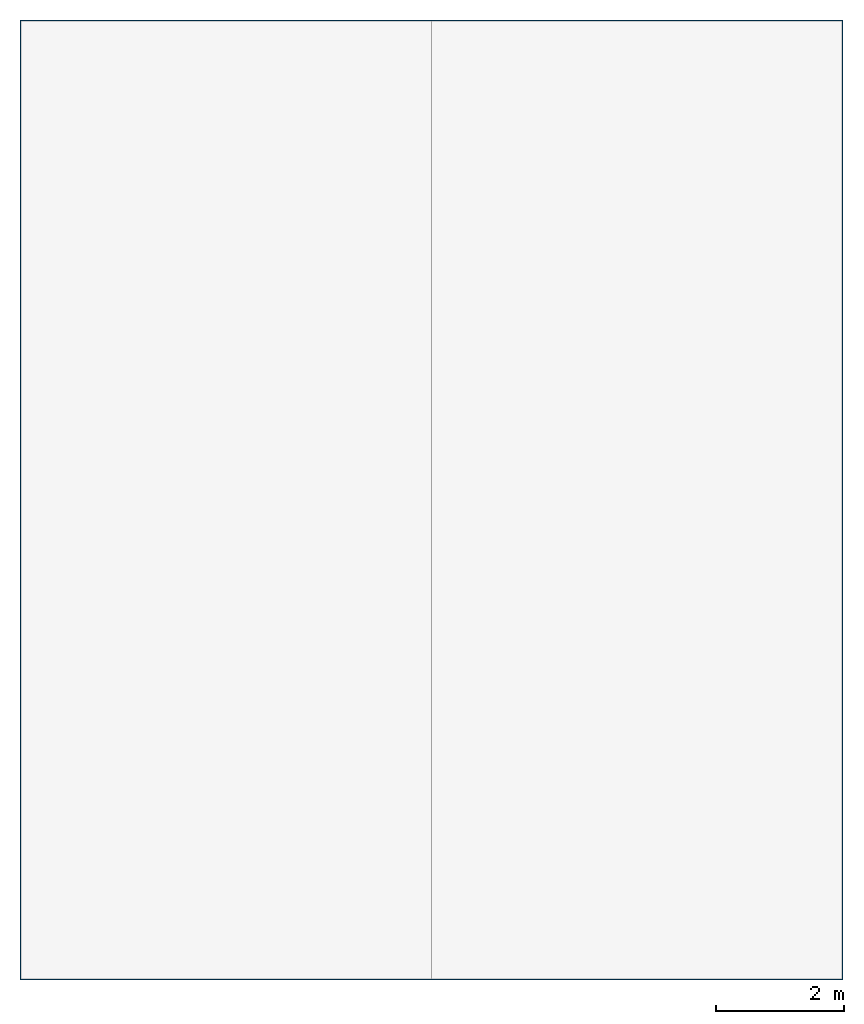
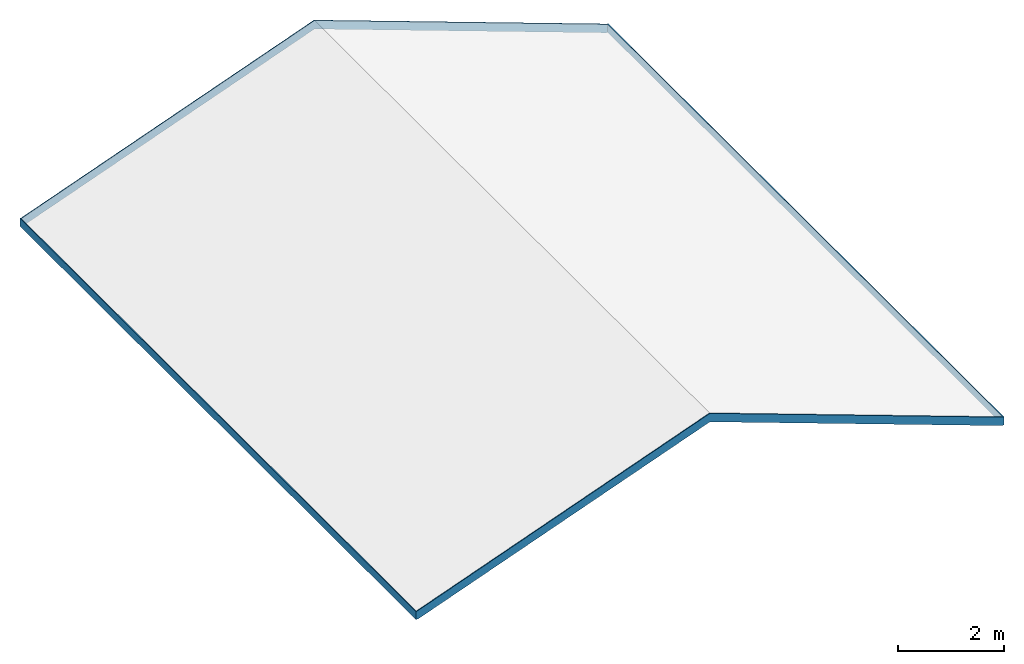
# One storey, part 2 of 2: 1 roof.
"""IFC2X3 building model written with IfcOpenShell, lengths in feet."""

from ifc_helpers import new_model, entity, si_unit, converted_unit, derived_unit, direction, frame, origin, place, context, subcontext, project, spatial, faceted_brep, material, type_object, element, save


model = new_model("IFC2X3")

# Units and contexts
model_context = context("Model", 3, precision=0.0001, world=origin(), true_north=direction((6.123031769111886e-17, 1.0)))
body_context = subcontext(model_context, "Body", "Model", "MODEL_VIEW")
ifc_project = project(units=[converted_unit("LENGTHUNIT", "FOOT", entity("IfcLengthMeasure", 0.3048), si_unit("LENGTHUNIT", "METRE"), dimensions=[1, 0, 0, 0, 0, 0, 0]), converted_unit("AREAUNIT", "SQUARE FOOT", entity("IfcAreaMeasure", 0.09290304), si_unit("AREAUNIT", "SQUARE_METRE"), dimensions=[2, 0, 0, 0, 0, 0, 0]), converted_unit("VOLUMEUNIT", "CUBIC FOOT", entity("IfcVolumeMeasure", 0.028316846592000004), si_unit("VOLUMEUNIT", "CUBIC_METRE"), dimensions=[3, 0, 0, 0, 0, 0, 0]), converted_unit("PLANEANGLEUNIT", "DEGREE", entity("IfcPlaneAngleMeasure", 0.017453292519943278), si_unit("PLANEANGLEUNIT", "RADIAN"), dimensions=[0, 0, 0, 0, 0, 0, 0]), si_unit("MASSUNIT", "GRAM", prefix="KILO"), derived_unit("MASSDENSITYUNIT", [(si_unit("MASSUNIT", "GRAM", prefix="KILO"), 1), (si_unit("LENGTHUNIT", "METRE"), -3)]), derived_unit("IONCONCENTRATIONUNIT", [(si_unit("MASSUNIT", "GRAM", prefix="KILO"), 1), (si_unit("LENGTHUNIT", "METRE"), -3)]), derived_unit("MOMENTOFINERTIAUNIT", [(si_unit("LENGTHUNIT", "METRE"), 4)]), si_unit("TIMEUNIT", "SECOND"), si_unit("FREQUENCYUNIT", "HERTZ"), si_unit("THERMODYNAMICTEMPERATUREUNIT", "DEGREE_CELSIUS"), derived_unit("THERMALTRANSMITTANCEUNIT", [(si_unit("MASSUNIT", "GRAM", prefix="KILO"), 1), (si_unit("THERMODYNAMICTEMPERATUREUNIT", "KELVIN"), -1), (si_unit("TIMEUNIT", "SECOND"), -3)]), derived_unit("THERMALCONDUCTANCEUNIT", [(si_unit("MASSUNIT", "GRAM", prefix="KILO"), 1), (si_unit("THERMODYNAMICTEMPERATUREUNIT", "KELVIN"), -1), (si_unit("TIMEUNIT", "SECOND"), -3), (si_unit("LENGTHUNIT", "METRE"), 1)]), derived_unit("VOLUMETRICFLOWRATEUNIT", [(si_unit("LENGTHUNIT", "METRE"), 3), (si_unit("TIMEUNIT", "SECOND"), -1)]), derived_unit("MASSFLOWRATEUNIT", [(si_unit("MASSUNIT", "GRAM", prefix="KILO"), 1), (si_unit("TIMEUNIT", "SECOND"), -1)]), derived_unit("ROTATIONALFREQUENCYUNIT", [(si_unit("TIMEUNIT", "SECOND"), -1)]), si_unit("ELECTRICCURRENTUNIT", "AMPERE"), si_unit("ELECTRICVOLTAGEUNIT", "VOLT"), si_unit("POWERUNIT", "WATT"), converted_unit("FORCEUNIT", "KIP", entity("IfcForceMeasure", 2.088543423315013e-05), si_unit("FORCEUNIT", "NEWTON"), dimensions=[1, 1, -2, 0, 0, 0, 0]), si_unit("ILLUMINANCEUNIT", "LUX"), si_unit("LUMINOUSFLUXUNIT", "LUMEN"), si_unit("LUMINOUSINTENSITYUNIT", "CANDELA"), si_unit("ENERGYUNIT", "JOULE"), derived_unit("USERDEFINED", [(si_unit("MASSUNIT", "GRAM", prefix="KILO"), -1), (si_unit("LENGTHUNIT", "METRE"), -2), (si_unit("TIMEUNIT", "SECOND"), 3), (si_unit("LUMINOUSFLUXUNIT", "LUMEN"), 1)]), derived_unit("USERDEFINED", [(si_unit("MASSUNIT", "GRAM", prefix="KILO"), 1), (si_unit("TIMEUNIT", "SECOND"), -3), (si_unit("LENGTHUNIT", "METRE"), 3), (si_unit("ELECTRICCURRENTUNIT", "AMPERE"), -2)]), derived_unit("SOUNDPOWERUNIT", [(si_unit("MASSUNIT", "GRAM", prefix="KILO"), 1), (si_unit("TIMEUNIT", "SECOND"), -3), (si_unit("LENGTHUNIT", "METRE"), 2)]), derived_unit("SOUNDPRESSUREUNIT", [(si_unit("MASSUNIT", "GRAM", prefix="KILO"), 1), (si_unit("LENGTHUNIT", "METRE"), -1), (si_unit("TIMEUNIT", "SECOND"), -2)]), derived_unit("LINEARVELOCITYUNIT", [(si_unit("LENGTHUNIT", "METRE"), 1), (si_unit("TIMEUNIT", "SECOND"), -1)]), si_unit("PRESSUREUNIT", "PASCAL"), derived_unit("USERDEFINED", [(si_unit("MASSUNIT", "GRAM", prefix="KILO"), 1), (si_unit("LENGTHUNIT", "METRE"), -2), (si_unit("TIMEUNIT", "SECOND"), -2)]), derived_unit("LINEARFORCEUNIT", [(si_unit("MASSUNIT", "GRAM", prefix="KILO"), 1), (si_unit("TIMEUNIT", "SECOND"), -2)]), derived_unit("PLANARFORCEUNIT", [(si_unit("MASSUNIT", "GRAM", prefix="KILO"), 1), (si_unit("LENGTHUNIT", "METRE"), -1), (si_unit("TIMEUNIT", "SECOND"), -2)]), derived_unit("SPECIFICHEATCAPACITYUNIT", [(si_unit("THERMODYNAMICTEMPERATUREUNIT", "KELVIN"), -1), (si_unit("LENGTHUNIT", "METRE"), 2), (si_unit("TIMEUNIT", "SECOND"), -2)]), derived_unit("HEATFLUXDENSITYUNIT", [(si_unit("MASSUNIT", "GRAM", prefix="KILO"), 1), (si_unit("TIMEUNIT", "SECOND"), -3)]), derived_unit("HEATINGVALUEUNIT", [(si_unit("LENGTHUNIT", "METRE"), 2), (si_unit("TIMEUNIT", "SECOND"), -2)]), derived_unit("VAPORPERMEABILITYUNIT", [(si_unit("LENGTHUNIT", "METRE"), -1), (si_unit("TIMEUNIT", "SECOND"), 1)]), derived_unit("DYNAMICVISCOSITYUNIT", [(si_unit("MASSUNIT", "GRAM", prefix="KILO"), 1), (si_unit("TIMEUNIT", "SECOND"), -1), (si_unit("LENGTHUNIT", "METRE"), -1)]), derived_unit("THERMALEXPANSIONCOEFFICIENTUNIT", [(si_unit("THERMODYNAMICTEMPERATUREUNIT", "KELVIN"), -1)]), derived_unit("MODULUSOFELASTICITYUNIT", [(si_unit("MASSUNIT", "GRAM", prefix="KILO"), 1), (si_unit("LENGTHUNIT", "METRE"), -1), (si_unit("TIMEUNIT", "SECOND"), -2)]), derived_unit("ISOTHERMALMOISTURECAPACITYUNIT", [(si_unit("LENGTHUNIT", "METRE"), 3), (si_unit("MASSUNIT", "GRAM", prefix="KILO"), -1)]), derived_unit("MOISTUREDIFFUSIVITYUNIT", [(si_unit("TIMEUNIT", "SECOND"), -1), (si_unit("LENGTHUNIT", "METRE"), 2)]), derived_unit("MASSPERLENGTHUNIT", [(si_unit("MASSUNIT", "GRAM", prefix="KILO"), 1), (si_unit("LENGTHUNIT", "METRE"), -1)]), derived_unit("THERMALRESISTANCEUNIT", [(si_unit("MASSUNIT", "GRAM", prefix="KILO"), -1), (si_unit("TIMEUNIT", "SECOND"), 3), (si_unit("THERMODYNAMICTEMPERATUREUNIT", "KELVIN"), 1)]), derived_unit("ACCELERATIONUNIT", [(si_unit("LENGTHUNIT", "METRE"), 1), (si_unit("TIMEUNIT", "SECOND"), -2)]), derived_unit("ANGULARVELOCITYUNIT", [(si_unit("TIMEUNIT", "SECOND"), -1), (si_unit("PLANEANGLEUNIT", "RADIAN"), 1)]), derived_unit("LINEARSTIFFNESSUNIT", [(si_unit("MASSUNIT", "GRAM", prefix="KILO"), 1), (si_unit("TIMEUNIT", "SECOND"), -2)]), derived_unit("WARPINGCONSTANTUNIT", [(si_unit("LENGTHUNIT", "METRE"), 6)]), derived_unit("LINEARMOMENTUNIT", [(si_unit("MASSUNIT", "GRAM", prefix="KILO"), 1), (si_unit("LENGTHUNIT", "METRE"), 1), (si_unit("TIMEUNIT", "SECOND"), -2)]), derived_unit("TORQUEUNIT", [(si_unit("MASSUNIT", "GRAM", prefix="KILO"), 1), (si_unit("LENGTHUNIT", "METRE"), 2), (si_unit("TIMEUNIT", "SECOND"), -2)])], contexts=[model_context])

# Site, building, storey
site_placement = place(None, origin())
site = spatial("IfcSite", under=ifc_project, at=site_placement, CompositionType="ELEMENT")
building_placement = place(site_placement, origin())
building = spatial("IfcBuilding", under=site, at=building_placement, CompositionType="ELEMENT")
storey_placement = place(building_placement, frame((0.0, 0.0, 28.25000000000186)))
storey = spatial("IfcBuildingStorey", under=building, at=storey_placement, Name="Third Floor", CompositionType="ELEMENT", Elevation=28.25000000000186)

# Roof
ifc_material = material(Name="Gypsum Wall Board")
type_product = type_object("IfcTypeProduct", Name="Fascia:Fascia-Flat 1x12")
roof_placement = place(storey_placement, frame((7.8119780191631705, -51.90374484724978, -0.1607592614683746)))
element("IfcRoof", 1, at=roof_placement, inside=storey, type_object=type_product, material=ifc_material, Name="Fascia:Fascia-Flat 1x12", ObjectType="Fascia:Fascia-Flat 1x12", ShapeType="NOTDEFINED", context=body_context, shape_type="Brep", body=[
    faceted_brep([(42.062500000000156, 0.06250000000001421, 0.6041666666666714), (42.125000000000156, 0.0, 0.6041666666666714), (42.125000000000156, 49.12500000000021, 0.6041666666666714), (42.06250000000015, 49.062500000000206, 0.6041666666666714), (42.062500000000156, 0.06250000000001421, 0.0), (42.062500000000156, 49.06250000000021, 0.0), (42.125000000000156, 0.0, 0.0), (42.12500000000016, 49.12500000000023, 0.0), (42.062500000000156, 49.12500000000021, 0.6041666666666714), (41.95596911582212, 49.06250000000021, 0.0), (41.95596911582212, 49.12500000000022, 0.0), (21.06250000000012, 49.12500000000021, 8.247541586256972), (21.062500000000124, 49.062500000000206, 8.247541586256972), (21.062500000000128, 49.06250000000021, 7.604600848719443), (21.062500000000128, 49.12500000000022, 7.604600848719443), (0.06250000000001066, 49.12500000000021, 0.6041666666666785), (0.06250000000001066, 49.06250000000021, 0.604166666666675), (0.16903088417804213, 49.06250000000021, 0.0), (0.16903088417804213, 49.12500000000022, 0.0), (0.0, 49.12500000000021, 0.6041666666666785), (0.06250000000001243, 49.06250000000021, 0.0), (0.0, 49.12500000000022, 0.0), (0.0, 0.0, 0.6041666666666785), (0.06250000000001865, 0.06250000000001421, 0.6041666666666714), (0.06250000000001421, 0.06250000000001421, 0.0), (0.0, 0.0, 0.0), (0.06250000000001332, 0.0, 0.6041666666666785), (0.1690308841780448, 0.0625000000000071, 0.0), (0.1690308841780439, 0.0, 0.0), (21.062500000000128, 0.0, 8.247541586256986), (21.06250000000013, 0.06250000000001421, 8.247541586256972), (21.062500000000128, 0.0625000000000071, 7.604600848719443), (21.062500000000128, 0.0, 7.604600848719457), (42.06250000000016, 0.0, 0.6041666666666679), (41.955969115822136, 0.06250000000001421, 0.0), (41.955969115822136, 0.0, 0.0)], [[[0, 1, 2, 3]], [[4, 0, 3, 5]], [[6, 4, 5, 7]], [[1, 6, 7, 2]], [[3, 2, 8]], [[5, 3, 9]], [[7, 5, 9, 10]], [[2, 7, 10, 8]], [[3, 8, 11, 12]], [[9, 3, 12, 13]], [[10, 9, 13, 14]], [[8, 10, 14, 11]], [[12, 11, 15, 16]], [[13, 12, 16, 17]], [[14, 13, 17, 18]], [[11, 14, 18, 15]], [[16, 15, 19]], [[17, 16, 20]], [[18, 17, 20, 21]], [[15, 18, 21, 19]], [[16, 19, 22, 23]], [[20, 16, 23, 24]], [[21, 20, 24, 25]], [[19, 21, 25, 22]], [[23, 22, 26]], [[24, 23, 27]], [[25, 24, 27, 28]], [[22, 25, 28, 26]], [[23, 26, 29, 30]], [[27, 23, 30, 31]], [[28, 27, 31, 32]], [[26, 28, 32, 29]], [[30, 29, 33, 0]], [[31, 30, 0, 34]], [[32, 31, 34, 35]], [[29, 32, 35, 33]], [[0, 33, 1]], [[34, 0, 4]], [[35, 34, 4, 6]], [[33, 35, 6, 1]]]),
])

save(model, "model.ifc")
